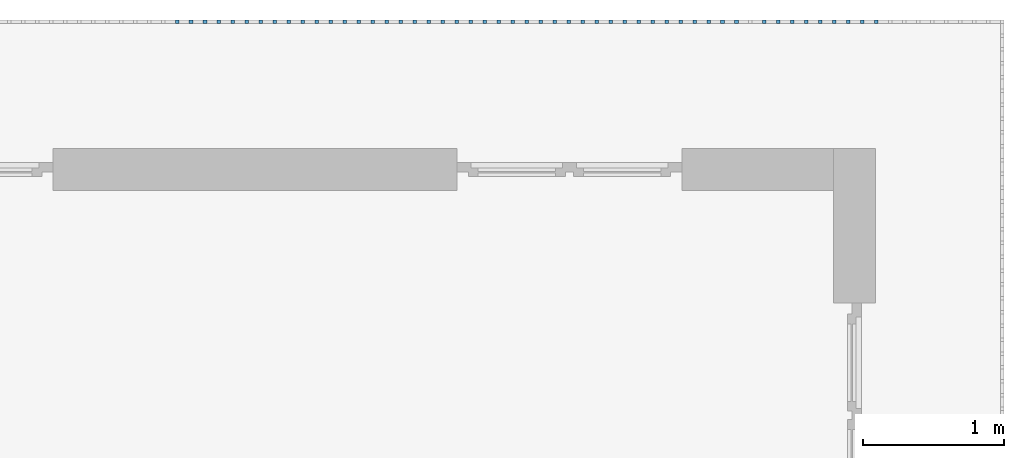
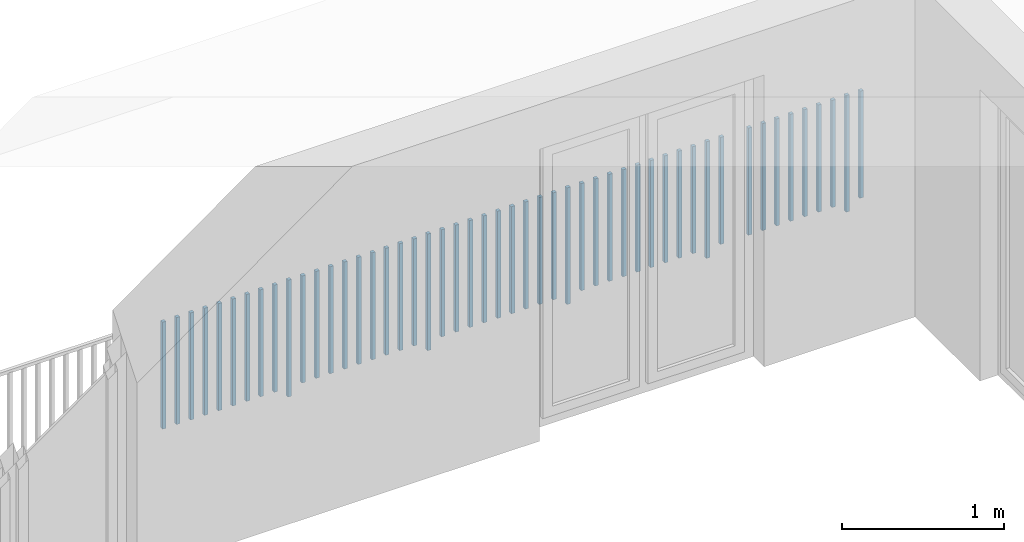
# One storey, part 47 of 48: 50 building element parts, 1 element without a shape of its own.
"""IFC4 building model written with IfcOpenShell, lengths in metres."""

import ifcopenshell
import ifcopenshell.guid

model = None  # the IFC model being written
_history = None  # IfcOwnerHistory: only IFC2X3 demands one
_inside = {}  # id of a spatial element -> (the spatial element, [elements in it])
_under = {}  # id of a project, library or spatial element -> (it, [spatial elements below it])
_declared = {}  # id of a project -> (the project, [libraries it declares])
_typed = {}  # id of a type object -> (the type object, [elements of that type])
_made_of = {}  # id of a material, layer set ... -> (it, [elements and type objects made of it])


def new_model(schema):
    """Start an empty IFC model of exactly this schema.

    Asked for "IFC4X3", IfcOpenShell would pick the latest addendum, in which some entities
    have other attributes; the version numbers below select the first issue.
    IFC2X3 requires an IfcOwnerHistory on every rooted entity: one is made here for all.
    """
    global model, _history
    if schema == "IFC4X3":
        model = ifcopenshell.file(schema_version=(4, 3, 0, 0))
    else:
        model = ifcopenshell.file(schema=schema)
    _inside.clear()
    _under.clear()
    _declared.clear()
    _typed.clear()
    _made_of.clear()
    _history = None
    if model.schema == "IFC2X3":
        org = make("IfcOrganization", Name="unknown")
        user = make(
            "IfcPersonAndOrganization",
            ThePerson=make("IfcPerson", FamilyName="unknown"),
            TheOrganization=org,
        )
        app = make(
            "IfcApplication",
            ApplicationDeveloper=org,
            Version="unknown",
            ApplicationFullName="unknown",
            ApplicationIdentifier="unknown",
        )
        _history = make(
            "IfcOwnerHistory",
            OwningUser=user,
            OwningApplication=app,
            ChangeAction="ADDED",
            CreationDate=0,
        )
    return model


def make(cls, **values):
    """One entity of the class cls with the attributes given. An attribute that is None is left unset."""
    return model.create_entity(
        cls, **{name: value for name, value in values.items() if value is not None}
    )


def entity(cls, *values):
    """Any entity or typed value of the class cls, its attributes in the order of the schema. None: left unset."""
    e = model.create_entity(cls)
    for i, value in enumerate(values):
        if value is not None:
            e[i] = value
    return e


def rooted(cls, **values):
    """An entity with a GlobalId (a new one), such as an element, a storey or a relation."""
    return make(cls, GlobalId=ifcopenshell.guid.new(), OwnerHistory=_history, **values)


def si_unit(unit_type, name, prefix=None):
    """IfcSIUnit, for example si_unit("LENGTHUNIT", "METRE", prefix="MILLI")."""
    return make("IfcSIUnit", UnitType=unit_type, Prefix=prefix, Name=name)


def converted_unit(unit_type, name, factor, base, dimensions=None, offset=None):
    """IfcConversionBasedUnit, such as the inch: factor (a typed value) times the base unit."""
    return make(
        "IfcConversionBasedUnit"
        if offset is None
        else "IfcConversionBasedUnitWithOffset",
        ConversionOffset=offset,
        Dimensions=None
        if dimensions is None
        else entity("IfcDimensionalExponents", *dimensions),
        UnitType=unit_type,
        Name=name,
        ConversionFactor=make(
            "IfcMeasureWithUnit", ValueComponent=factor, UnitComponent=base
        ),
    )


def derived_unit(unit_type, elements):
    """IfcDerivedUnit: a product of units, each with its exponent."""
    return make(
        "IfcDerivedUnit",
        Elements=[
            make("IfcDerivedUnitElement", Unit=unit, Exponent=power)
            for unit, power in elements
        ],
        UnitType=unit_type,
    )


def assignment(units):
    """IfcUnitAssignment: the units of a project."""
    return None if units is None else make("IfcUnitAssignment", Units=units)


def point(xyz):
    """IfcCartesianPoint."""
    return None if xyz is None else make("IfcCartesianPoint", Coordinates=xyz)


def direction(xyz):
    """IfcDirection."""
    return None if xyz is None else make("IfcDirection", DirectionRatios=xyz)


def frame(location, z_axis=None, x_axis=None):
    """IfcAxis2Placement3D, a coordinate frame: its origin and axes. An axis left out is left unset."""
    return make(
        "IfcAxis2Placement3D",
        Location=point(location),
        Axis=direction(z_axis),
        RefDirection=direction(x_axis),
    )


def origin_with_axes():
    """The frame at (0, 0, 0) with the z axis (0, 0, 1) and the x axis (1, 0, 0) written out."""
    return frame((0.0, 0.0, 0.0), z_axis=(0.0, 0.0, 1.0), x_axis=(1.0, 0.0, 0.0))


def place(relative_to, where):
    """IfcLocalPlacement: puts the frame where relative to a parent placement (None: the world)."""
    return make(
        "IfcLocalPlacement", PlacementRelTo=relative_to, RelativePlacement=where
    )


def context(
    kind, dimensions, precision=None, world=None, true_north=None, identifier=None
):
    """IfcGeometricRepresentationContext, for example the 3D "Model" context."""
    return make(
        "IfcGeometricRepresentationContext",
        ContextIdentifier=identifier,
        ContextType=kind,
        CoordinateSpaceDimension=dimensions,
        Precision=precision,
        WorldCoordinateSystem=world,
        TrueNorth=true_north,
    )


def subcontext(parent, identifier, kind, view, scale=None):
    """IfcGeometricRepresentationSubContext, for example "Body" below "Model"."""
    return make(
        "IfcGeometricRepresentationSubContext",
        ContextIdentifier=identifier,
        ContextType=kind,
        ParentContext=parent,
        TargetScale=scale,
        TargetView=view,
    )


def project(units=None, contexts=None):
    """IfcProject with its units and contexts."""
    return rooted(
        "IfcProject",
        Name="project",
        RepresentationContexts=contexts,
        UnitsInContext=assignment(units),
    )


def spatial(cls, under=None, at=None, **own):
    """A site, building, storey or space (cls), placed at a placement, below another one or the project."""
    s = rooted(cls, ObjectPlacement=at, **own)
    if under is not None:
        _under.setdefault(under.id(), (under, []))[1].append(s)
    return s


def point_list(points):
    """IfcCartesianPointList2D or 3D."""
    cls = (
        "IfcCartesianPointList2D" if len(points[0]) == 2 else "IfcCartesianPointList3D"
    )
    return make(cls, CoordList=points)


def polygons(points, faces, closed=None, point_numbers=None):
    """IfcPolygonalFaceSet: a face is its outer loop, then its inner loops; points numbered from 1."""
    made = []
    for loops in faces:
        if len(loops) == 1:
            made.append(make("IfcIndexedPolygonalFace", CoordIndex=loops[0]))
        else:
            made.append(
                make(
                    "IfcIndexedPolygonalFaceWithVoids",
                    CoordIndex=loops[0],
                    InnerCoordIndices=loops[1:],
                )
            )
    return make(
        "IfcPolygonalFaceSet",
        Coordinates=point_list(points),
        Closed=closed,
        Faces=made,
        PnIndex=point_numbers,
    )


def shape(context_of_items, identifier, shape_type, items):
    """IfcShapeRepresentation: the items that make up one representation, for example the "Body"."""
    return make(
        "IfcShapeRepresentation",
        ContextOfItems=context_of_items,
        RepresentationIdentifier=identifier,
        RepresentationType=shape_type,
        Items=items,
    )


def material(Name=None, Category=None):
    """IfcMaterial."""
    return make("IfcMaterial", Name=Name, Category=Category)


def made_of(thing, what):
    """Note that an element or type object is made of a material, layer set ...; save() writes the relation."""
    if what is not None:
        _made_of.setdefault(what.id(), (what, []))[1].append(thing)
    return thing


def type_object(cls, material=None, **own):
    """A type object (cls), such as IfcWallType, which elements share."""
    return made_of(rooted(cls, **own), material)


def element(
    cls,
    number,
    at=None,
    inside=None,
    cuts=None,
    type_object=None,
    material=None,
    context=None,
    identifier="Body",
    shape_type=None,
    held_by="IfcProductDefinitionShape",
    body=None,
    shapes=None,
    **own,
):
    """One element of the class cls, such as IfcWall. Its Tag is "e" and its number.

    at: its placement. inside: the storey or other place that contains it. cuts: it is an
    opening in that element (IfcRelVoidsElement). A single representation is given by context,
    identifier, shape_type and body (its items); several are given by shapes. held_by: the class
    of the entity that holds the representations. save() writes the other relations.
    """
    e = rooted(cls, Tag="e%d" % number, ObjectPlacement=at, **own)
    if body is not None:
        shapes = [shape(context, identifier, shape_type, body)]
    if shapes is not None:
        e.Representation = make(held_by, Representations=shapes)
    if inside is not None:
        _inside.setdefault(inside.id(), (inside, []))[1].append(e)
    if cuts is not None:
        rooted(
            "IfcRelVoidsElement", RelatingBuildingElement=cuts, RelatedOpeningElement=e
        )
    if type_object is not None:
        _typed.setdefault(type_object.id(), (type_object, []))[1].append(e)
    return made_of(e, material)


def aggregate(whole, parts):
    """IfcRelAggregates: a whole, such as a stair, and the parts it consists of."""
    return rooted("IfcRelAggregates", RelatingObject=whole, RelatedObjects=parts)


def save(model, path):
    """Write the relations noted so far, then the file.

    IfcRelAggregates (storeys below a building ...), IfcRelContainedInSpatialStructure (elements
    in a storey), IfcRelDefinesByType, IfcRelAssociatesMaterial and IfcRelDeclares: one each for
    every whole, place, type object, material and project.
    """
    for whole, parts in _under.values():
        aggregate(whole, parts)
    for where, things in _inside.values():
        rooted(
            "IfcRelContainedInSpatialStructure",
            RelatedElements=things,
            RelatingStructure=where,
        )
    for kind, things in _typed.values():
        rooted("IfcRelDefinesByType", RelatedObjects=things, RelatingType=kind)
    for what, things in _made_of.values():
        rooted("IfcRelAssociatesMaterial", RelatedObjects=things, RelatingMaterial=what)
    for by, libraries in _declared.values():
        rooted("IfcRelDeclares", RelatingContext=by, RelatedDefinitions=libraries)
    model.write(path)


model = new_model("IFC4")

# Units and contexts
model_context = context("Model", 3, precision=1e-05, world=origin_with_axes(), true_north=direction((0.0, 1.0)))
body_context = subcontext(model_context, "Body", "Model", "MODEL_VIEW")
ifc_project = project(units=[si_unit("LENGTHUNIT", "METRE"), si_unit("AREAUNIT", "SQUARE_METRE"), si_unit("VOLUMEUNIT", "CUBIC_METRE"), converted_unit("PLANEANGLEUNIT", "DEGREE", entity("IfcPlaneAngleMeasure", 0.0174532925199), si_unit("PLANEANGLEUNIT", "RADIAN"), dimensions=[0, 0, 0, 0, 0, 0, 0]), converted_unit("TIMEUNIT", "Year", entity("IfcTimeMeasure", 31556926.0), si_unit("TIMEUNIT", "SECOND"), dimensions=[0, 0, 1, 0, 0, 0, 0]), si_unit("MASSUNIT", "GRAM", prefix="KILO"), si_unit("THERMODYNAMICTEMPERATUREUNIT", "DEGREE_CELSIUS"), si_unit("LUMINOUSINTENSITYUNIT", "LUMEN"), si_unit("ENERGYUNIT", "JOULE", prefix="MEGA"), derived_unit("THERMALCONDUCTANCEUNIT", [(si_unit("POWERUNIT", "WATT"), 1), (si_unit("LENGTHUNIT", "METRE"), -1), (si_unit("THERMODYNAMICTEMPERATUREUNIT", "KELVIN"), -1)]), derived_unit("SPECIFICHEATCAPACITYUNIT", [(si_unit("ENERGYUNIT", "JOULE"), 1), (si_unit("MASSUNIT", "GRAM", prefix="KILO"), -1), (si_unit("THERMODYNAMICTEMPERATUREUNIT", "KELVIN"), -1)]), derived_unit("MASSDENSITYUNIT", [(si_unit("MASSUNIT", "GRAM", prefix="KILO"), 1), (si_unit("VOLUMEUNIT", "CUBIC_METRE"), -1)])], contexts=[model_context])

# Site, building, storey
site_placement = place(None, origin_with_axes())
site = spatial("IfcSite", under=ifc_project, at=site_placement, CompositionType="ELEMENT")
building_placement = place(site_placement, origin_with_axes())
building = spatial("IfcBuilding", under=site, at=building_placement, CompositionType="ELEMENT")
storey_placement = place(building_placement, frame((0.0, 0.0, 3.4), z_axis=(0.0, 0.0, 1.0), x_axis=(1.0, 0.0, 0.0)))
storey = spatial("IfcBuildingStorey", under=building, at=storey_placement, Name="1. Geschoss", CompositionType="ELEMENT", Elevation=3.4)

# Railing, building element parts
railing_type = type_object("IfcRailingType", PredefinedType="NOTDEFINED")
railing_placement = place(storey_placement, frame((10.2378006196, 9.82118776896, 0.0), z_axis=(0.0, 0.0, 1.0), x_axis=(1.0, 0.0, 0.0)))
railing = element("IfcRailing", 1, at=railing_placement, inside=storey, type_object=railing_type, PredefinedType="NOTDEFINED")
ifc_material = material()
building_element_part_1_placement = place(railing_placement, origin_with_axes())
building_element_part_1 = element("IfcBuildingElementPart", 2, at=building_element_part_1_placement, material=ifc_material, PredefinedType="NOTDEFINED", context=body_context, shape_type="Tessellation", body=[
    polygons([(-0.907804347826, 0.0125, 0.07), (-0.907804347826, -0.0125, 0.07), (-0.907804347826, -0.0125, 0.8775), (-0.907804347826, 0.0125, 0.8775), (-0.882804347826, 0.0125, 0.07), (-0.882804347826, -0.0125, 0.07), (-0.882804347826, -0.0125, 0.8775), (-0.882804347826, 0.0125, 0.8775)], [[[1, 2, 3, 4]], [[1, 5, 6, 2]], [[2, 6, 7, 3]], [[4, 3, 7, 8]], [[5, 1, 4, 8]], [[6, 5, 8, 7]]], closed=True),
])
building_element_part_2_placement = place(railing_placement, origin_with_axes())
building_element_part_2 = element("IfcBuildingElementPart", 3, at=building_element_part_2_placement, material=ifc_material, PredefinedType="NOTDEFINED", context=body_context, shape_type="Tessellation", body=[
    polygons([(-1.0072826087, 0.0125, 0.0), (-1.0072826087, -0.0125, 0.0), (-1.0072826087, -0.0125, 0.88), (-1.0072826087, 0.0125, 0.88), (-0.982282608696, 0.0125, 0.0), (-0.982282608696, -0.0125, 0.0), (-0.982282608696, -0.0125, 0.88), (-0.982282608696, 0.0125, 0.88)], [[[1, 2, 3, 4]], [[1, 5, 6, 2]], [[2, 6, 7, 3]], [[4, 3, 7, 8]], [[5, 1, 4, 8]], [[6, 5, 8, 7]]], closed=True),
])
building_element_part_3_placement = place(railing_placement, origin_with_axes())
building_element_part_3 = element("IfcBuildingElementPart", 4, at=building_element_part_3_placement, material=ifc_material, PredefinedType="NOTDEFINED", context=body_context, shape_type="Tessellation", body=[
    polygons([(-1.10676086957, 0.0125, 0.07), (-1.10676086957, -0.0125, 0.07), (-1.10676086957, -0.0125, 0.8775), (-1.10676086957, 0.0125, 0.8775), (-1.08176086957, 0.0125, 0.07), (-1.08176086957, -0.0125, 0.07), (-1.08176086957, -0.0125, 0.8775), (-1.08176086957, 0.0125, 0.8775)], [[[1, 2, 3, 4]], [[1, 5, 6, 2]], [[2, 6, 7, 3]], [[4, 3, 7, 8]], [[5, 1, 4, 8]], [[6, 5, 8, 7]]], closed=True),
])
building_element_part_4_placement = place(railing_placement, origin_with_axes())
building_element_part_4 = element("IfcBuildingElementPart", 5, at=building_element_part_4_placement, material=ifc_material, PredefinedType="NOTDEFINED", context=body_context, shape_type="Tessellation", body=[
    polygons([(-1.20623913043, 0.0125, 0.07), (-1.20623913043, -0.0125, 0.07), (-1.20623913043, -0.0125, 0.8775), (-1.20623913043, 0.0125, 0.8775), (-1.18123913043, 0.0125, 0.07), (-1.18123913043, -0.0125, 0.07), (-1.18123913043, -0.0125, 0.8775), (-1.18123913043, 0.0125, 0.8775)], [[[1, 2, 3, 4]], [[1, 5, 6, 2]], [[2, 6, 7, 3]], [[4, 3, 7, 8]], [[5, 1, 4, 8]], [[6, 5, 8, 7]]], closed=True),
])
building_element_part_5_placement = place(railing_placement, origin_with_axes())
building_element_part_5 = element("IfcBuildingElementPart", 6, at=building_element_part_5_placement, material=ifc_material, PredefinedType="NOTDEFINED", context=body_context, shape_type="Tessellation", body=[
    polygons([(-1.3057173913, 0.0125, 0.07), (-1.3057173913, -0.0125, 0.07), (-1.3057173913, -0.0125, 0.8775), (-1.3057173913, 0.0125, 0.8775), (-1.2807173913, 0.0125, 0.07), (-1.2807173913, -0.0125, 0.07), (-1.2807173913, -0.0125, 0.8775), (-1.2807173913, 0.0125, 0.8775)], [[[1, 2, 3, 4]], [[1, 5, 6, 2]], [[2, 6, 7, 3]], [[4, 3, 7, 8]], [[5, 1, 4, 8]], [[6, 5, 8, 7]]], closed=True),
])
building_element_part_6_placement = place(railing_placement, origin_with_axes())
building_element_part_6 = element("IfcBuildingElementPart", 7, at=building_element_part_6_placement, material=ifc_material, PredefinedType="NOTDEFINED", context=body_context, shape_type="Tessellation", body=[
    polygons([(-1.40519565217, 0.0125, 0.07), (-1.40519565217, -0.0125, 0.07), (-1.40519565217, -0.0125, 0.8775), (-1.40519565217, 0.0125, 0.8775), (-1.38019565217, 0.0125, 0.07), (-1.38019565217, -0.0125, 0.07), (-1.38019565217, -0.0125, 0.8775), (-1.38019565217, 0.0125, 0.8775)], [[[1, 2, 3, 4]], [[1, 5, 6, 2]], [[2, 6, 7, 3]], [[4, 3, 7, 8]], [[5, 1, 4, 8]], [[6, 5, 8, 7]]], closed=True),
])
building_element_part_7_placement = place(railing_placement, origin_with_axes())
building_element_part_7 = element("IfcBuildingElementPart", 8, at=building_element_part_7_placement, material=ifc_material, PredefinedType="NOTDEFINED", context=body_context, shape_type="Tessellation", body=[
    polygons([(-1.50467391304, 0.0125, 0.07), (-1.50467391304, -0.0125, 0.07), (-1.50467391304, -0.0125, 0.8775), (-1.50467391304, 0.0125, 0.8775), (-1.47967391304, 0.0125, 0.07), (-1.47967391304, -0.0125, 0.07), (-1.47967391304, -0.0125, 0.8775), (-1.47967391304, 0.0125, 0.8775)], [[[1, 2, 3, 4]], [[1, 5, 6, 2]], [[2, 6, 7, 3]], [[4, 3, 7, 8]], [[5, 1, 4, 8]], [[6, 5, 8, 7]]], closed=True),
])
building_element_part_8_placement = place(railing_placement, origin_with_axes())
building_element_part_8 = element("IfcBuildingElementPart", 9, at=building_element_part_8_placement, material=ifc_material, PredefinedType="NOTDEFINED", context=body_context, shape_type="Tessellation", body=[
    polygons([(-1.60415217391, 0.0125, 0.07), (-1.60415217391, -0.0125, 0.07), (-1.60415217391, -0.0125, 0.8775), (-1.60415217391, 0.0125, 0.8775), (-1.57915217391, 0.0125, 0.07), (-1.57915217391, -0.0125, 0.07), (-1.57915217391, -0.0125, 0.8775), (-1.57915217391, 0.0125, 0.8775)], [[[1, 2, 3, 4]], [[1, 5, 6, 2]], [[2, 6, 7, 3]], [[4, 3, 7, 8]], [[5, 1, 4, 8]], [[6, 5, 8, 7]]], closed=True),
])
building_element_part_9_placement = place(railing_placement, origin_with_axes())
building_element_part_9 = element("IfcBuildingElementPart", 10, at=building_element_part_9_placement, material=ifc_material, PredefinedType="NOTDEFINED", context=body_context, shape_type="Tessellation", body=[
    polygons([(-1.70363043478, 0.0125, 0.07), (-1.70363043478, -0.0125, 0.07), (-1.70363043478, -0.0125, 0.8775), (-1.70363043478, 0.0125, 0.8775), (-1.67863043478, 0.0125, 0.07), (-1.67863043478, -0.0125, 0.07), (-1.67863043478, -0.0125, 0.8775), (-1.67863043478, 0.0125, 0.8775)], [[[1, 2, 3, 4]], [[1, 5, 6, 2]], [[2, 6, 7, 3]], [[4, 3, 7, 8]], [[5, 1, 4, 8]], [[6, 5, 8, 7]]], closed=True),
])
building_element_part_10_placement = place(railing_placement, origin_with_axes())
building_element_part_10 = element("IfcBuildingElementPart", 11, at=building_element_part_10_placement, material=ifc_material, PredefinedType="NOTDEFINED", context=body_context, shape_type="Tessellation", body=[
    polygons([(-1.90258695652, 0.0125, 0.07), (-1.90258695652, -0.0125, 0.07), (-1.90258695652, -0.0125, 0.8775), (-1.90258695652, 0.0125, 0.8775), (-1.87758695652, 0.0125, 0.07), (-1.87758695652, -0.0125, 0.07), (-1.87758695652, -0.0125, 0.8775), (-1.87758695652, 0.0125, 0.8775)], [[[1, 2, 3, 4]], [[1, 5, 6, 2]], [[2, 6, 7, 3]], [[4, 3, 7, 8]], [[5, 1, 4, 8]], [[6, 5, 8, 7]]], closed=True),
])
building_element_part_11_placement = place(railing_placement, origin_with_axes())
building_element_part_11 = element("IfcBuildingElementPart", 12, at=building_element_part_11_placement, material=ifc_material, PredefinedType="NOTDEFINED", context=body_context, shape_type="Tessellation", body=[
    polygons([(-2.00206521739, 0.0125, 0.0), (-2.00206521739, -0.0125, 0.0), (-2.00206521739, -0.0125, 0.88), (-2.00206521739, 0.0125, 0.88), (-1.97706521739, 0.0125, 0.0), (-1.97706521739, -0.0125, 0.0), (-1.97706521739, -0.0125, 0.88), (-1.97706521739, 0.0125, 0.88)], [[[1, 2, 3, 4]], [[1, 5, 6, 2]], [[2, 6, 7, 3]], [[4, 3, 7, 8]], [[5, 1, 4, 8]], [[6, 5, 8, 7]]], closed=True),
])
building_element_part_12_placement = place(railing_placement, origin_with_axes())
building_element_part_12 = element("IfcBuildingElementPart", 13, at=building_element_part_12_placement, material=ifc_material, PredefinedType="NOTDEFINED", context=body_context, shape_type="Tessellation", body=[
    polygons([(-2.10154347826, 0.0125, 0.07), (-2.10154347826, -0.0125, 0.07), (-2.10154347826, -0.0125, 0.8775), (-2.10154347826, 0.0125, 0.8775), (-2.07654347826, 0.0125, 0.07), (-2.07654347826, -0.0125, 0.07), (-2.07654347826, -0.0125, 0.8775), (-2.07654347826, 0.0125, 0.8775)], [[[1, 2, 3, 4]], [[1, 5, 6, 2]], [[2, 6, 7, 3]], [[4, 3, 7, 8]], [[5, 1, 4, 8]], [[6, 5, 8, 7]]], closed=True),
])
building_element_part_13_placement = place(railing_placement, origin_with_axes())
building_element_part_13 = element("IfcBuildingElementPart", 14, at=building_element_part_13_placement, material=ifc_material, PredefinedType="NOTDEFINED", context=body_context, shape_type="Tessellation", body=[
    polygons([(-2.20102173913, 0.0125, 0.07), (-2.20102173913, -0.0125, 0.07), (-2.20102173913, -0.0125, 0.8775), (-2.20102173913, 0.0125, 0.8775), (-2.17602173913, 0.0125, 0.07), (-2.17602173913, -0.0125, 0.07), (-2.17602173913, -0.0125, 0.8775), (-2.17602173913, 0.0125, 0.8775)], [[[1, 2, 3, 4]], [[1, 5, 6, 2]], [[2, 6, 7, 3]], [[4, 3, 7, 8]], [[5, 1, 4, 8]], [[6, 5, 8, 7]]], closed=True),
])
building_element_part_14_placement = place(railing_placement, origin_with_axes())
building_element_part_14 = element("IfcBuildingElementPart", 15, at=building_element_part_14_placement, material=ifc_material, PredefinedType="NOTDEFINED", context=body_context, shape_type="Tessellation", body=[
    polygons([(-2.3005, 0.0125, 0.07), (-2.3005, -0.0125, 0.07), (-2.3005, -0.0125, 0.8775), (-2.3005, 0.0125, 0.8775), (-2.2755, 0.0125, 0.07), (-2.2755, -0.0125, 0.07), (-2.2755, -0.0125, 0.8775), (-2.2755, 0.0125, 0.8775)], [[[1, 2, 3, 4]], [[1, 5, 6, 2]], [[2, 6, 7, 3]], [[4, 3, 7, 8]], [[5, 1, 4, 8]], [[6, 5, 8, 7]]], closed=True),
])
building_element_part_15_placement = place(railing_placement, origin_with_axes())
building_element_part_15 = element("IfcBuildingElementPart", 16, at=building_element_part_15_placement, material=ifc_material, PredefinedType="NOTDEFINED", context=body_context, shape_type="Tessellation", body=[
    polygons([(-2.39997826087, 0.0125, 0.07), (-2.39997826087, -0.0125, 0.07), (-2.39997826087, -0.0125, 0.8775), (-2.39997826087, 0.0125, 0.8775), (-2.37497826087, 0.0125, 0.07), (-2.37497826087, -0.0125, 0.07), (-2.37497826087, -0.0125, 0.8775), (-2.37497826087, 0.0125, 0.8775)], [[[1, 2, 3, 4]], [[1, 5, 6, 2]], [[2, 6, 7, 3]], [[4, 3, 7, 8]], [[5, 1, 4, 8]], [[6, 5, 8, 7]]], closed=True),
])
building_element_part_16_placement = place(railing_placement, origin_with_axes())
building_element_part_16 = element("IfcBuildingElementPart", 17, at=building_element_part_16_placement, material=ifc_material, PredefinedType="NOTDEFINED", context=body_context, shape_type="Tessellation", body=[
    polygons([(-2.49945652174, 0.0125, 0.07), (-2.49945652174, -0.0125, 0.07), (-2.49945652174, -0.0125, 0.8775), (-2.49945652174, 0.0125, 0.8775), (-2.47445652174, 0.0125, 0.07), (-2.47445652174, -0.0125, 0.07), (-2.47445652174, -0.0125, 0.8775), (-2.47445652174, 0.0125, 0.8775)], [[[1, 2, 3, 4]], [[1, 5, 6, 2]], [[2, 6, 7, 3]], [[4, 3, 7, 8]], [[5, 1, 4, 8]], [[6, 5, 8, 7]]], closed=True),
])
building_element_part_17_placement = place(railing_placement, origin_with_axes())
building_element_part_17 = element("IfcBuildingElementPart", 18, at=building_element_part_17_placement, material=ifc_material, PredefinedType="NOTDEFINED", context=body_context, shape_type="Tessellation", body=[
    polygons([(-2.59893478261, 0.0125, 0.07), (-2.59893478261, -0.0125, 0.07), (-2.59893478261, -0.0125, 0.8775), (-2.59893478261, 0.0125, 0.8775), (-2.57393478261, 0.0125, 0.07), (-2.57393478261, -0.0125, 0.07), (-2.57393478261, -0.0125, 0.8775), (-2.57393478261, 0.0125, 0.8775)], [[[1, 2, 3, 4]], [[1, 5, 6, 2]], [[2, 6, 7, 3]], [[4, 3, 7, 8]], [[5, 1, 4, 8]], [[6, 5, 8, 7]]], closed=True),
])
building_element_part_18_placement = place(railing_placement, origin_with_axes())
building_element_part_18 = element("IfcBuildingElementPart", 19, at=building_element_part_18_placement, material=ifc_material, PredefinedType="NOTDEFINED", context=body_context, shape_type="Tessellation", body=[
    polygons([(-2.69841304348, 0.0125, 0.07), (-2.69841304348, -0.0125, 0.07), (-2.69841304348, -0.0125, 0.8775), (-2.69841304348, 0.0125, 0.8775), (-2.67341304348, 0.0125, 0.07), (-2.67341304348, -0.0125, 0.07), (-2.67341304348, -0.0125, 0.8775), (-2.67341304348, 0.0125, 0.8775)], [[[1, 2, 3, 4]], [[1, 5, 6, 2]], [[2, 6, 7, 3]], [[4, 3, 7, 8]], [[5, 1, 4, 8]], [[6, 5, 8, 7]]], closed=True),
])
building_element_part_19_placement = place(railing_placement, origin_with_axes())
building_element_part_19 = element("IfcBuildingElementPart", 20, at=building_element_part_19_placement, material=ifc_material, PredefinedType="NOTDEFINED", context=body_context, shape_type="Tessellation", body=[
    polygons([(-2.79789130435, 0.0125, 0.07), (-2.79789130435, -0.0125, 0.07), (-2.79789130435, -0.0125, 0.8775), (-2.79789130435, 0.0125, 0.8775), (-2.77289130435, 0.0125, 0.07), (-2.77289130435, -0.0125, 0.07), (-2.77289130435, -0.0125, 0.8775), (-2.77289130435, 0.0125, 0.8775)], [[[1, 2, 3, 4]], [[1, 5, 6, 2]], [[2, 6, 7, 3]], [[4, 3, 7, 8]], [[5, 1, 4, 8]], [[6, 5, 8, 7]]], closed=True),
])
building_element_part_20_placement = place(railing_placement, origin_with_axes())
building_element_part_20 = element("IfcBuildingElementPart", 21, at=building_element_part_20_placement, material=ifc_material, PredefinedType="NOTDEFINED", context=body_context, shape_type="Tessellation", body=[
    polygons([(-2.89736956522, 0.0125, 0.07), (-2.89736956522, -0.0125, 0.07), (-2.89736956522, -0.0125, 0.8775), (-2.89736956522, 0.0125, 0.8775), (-2.87236956522, 0.0125, 0.07), (-2.87236956522, -0.0125, 0.07), (-2.87236956522, -0.0125, 0.8775), (-2.87236956522, 0.0125, 0.8775)], [[[1, 2, 3, 4]], [[1, 5, 6, 2]], [[2, 6, 7, 3]], [[4, 3, 7, 8]], [[5, 1, 4, 8]], [[6, 5, 8, 7]]], closed=True),
])
building_element_part_21_placement = place(railing_placement, origin_with_axes())
building_element_part_21 = element("IfcBuildingElementPart", 22, at=building_element_part_21_placement, material=ifc_material, PredefinedType="NOTDEFINED", context=body_context, shape_type="Tessellation", body=[
    polygons([(-2.99684782609, 0.0125, 0.0), (-2.99684782609, -0.0125, 0.0), (-2.99684782609, -0.0125, 0.88), (-2.99684782609, 0.0125, 0.88), (-2.97184782609, 0.0125, 0.0), (-2.97184782609, -0.0125, 0.0), (-2.97184782609, -0.0125, 0.88), (-2.97184782609, 0.0125, 0.88)], [[[1, 2, 3, 4]], [[1, 5, 6, 2]], [[2, 6, 7, 3]], [[4, 3, 7, 8]], [[5, 1, 4, 8]], [[6, 5, 8, 7]]], closed=True),
])
building_element_part_22_placement = place(railing_placement, origin_with_axes())
building_element_part_22 = element("IfcBuildingElementPart", 23, at=building_element_part_22_placement, material=ifc_material, PredefinedType="NOTDEFINED", context=body_context, shape_type="Tessellation", body=[
    polygons([(-3.09632608696, 0.0125, 0.07), (-3.09632608696, -0.0125, 0.07), (-3.09632608696, -0.0125, 0.8775), (-3.09632608696, 0.0125, 0.8775), (-3.07132608696, 0.0125, 0.07), (-3.07132608696, -0.0125, 0.07), (-3.07132608696, -0.0125, 0.8775), (-3.07132608696, 0.0125, 0.8775)], [[[1, 2, 3, 4]], [[1, 5, 6, 2]], [[2, 6, 7, 3]], [[4, 3, 7, 8]], [[5, 1, 4, 8]], [[6, 5, 8, 7]]], closed=True),
])
building_element_part_23_placement = place(railing_placement, origin_with_axes())
building_element_part_23 = element("IfcBuildingElementPart", 24, at=building_element_part_23_placement, material=ifc_material, PredefinedType="NOTDEFINED", context=body_context, shape_type="Tessellation", body=[
    polygons([(-3.19580434783, 0.0125, 0.07), (-3.19580434783, -0.0125, 0.07), (-3.19580434783, -0.0125, 0.8775), (-3.19580434783, 0.0125, 0.8775), (-3.17080434783, 0.0125, 0.07), (-3.17080434783, -0.0125, 0.07), (-3.17080434783, -0.0125, 0.8775), (-3.17080434783, 0.0125, 0.8775)], [[[1, 2, 3, 4]], [[1, 5, 6, 2]], [[2, 6, 7, 3]], [[4, 3, 7, 8]], [[5, 1, 4, 8]], [[6, 5, 8, 7]]], closed=True),
])
building_element_part_24_placement = place(railing_placement, origin_with_axes())
building_element_part_24 = element("IfcBuildingElementPart", 25, at=building_element_part_24_placement, material=ifc_material, PredefinedType="NOTDEFINED", context=body_context, shape_type="Tessellation", body=[
    polygons([(-3.2952826087, 0.0125, 0.07), (-3.2952826087, -0.0125, 0.07), (-3.2952826087, -0.0125, 0.8775), (-3.2952826087, 0.0125, 0.8775), (-3.2702826087, 0.0125, 0.07), (-3.2702826087, -0.0125, 0.07), (-3.2702826087, -0.0125, 0.8775), (-3.2702826087, 0.0125, 0.8775)], [[[1, 2, 3, 4]], [[1, 5, 6, 2]], [[2, 6, 7, 3]], [[4, 3, 7, 8]], [[5, 1, 4, 8]], [[6, 5, 8, 7]]], closed=True),
])
building_element_part_25_placement = place(railing_placement, origin_with_axes())
building_element_part_25 = element("IfcBuildingElementPart", 26, at=building_element_part_25_placement, material=ifc_material, PredefinedType="NOTDEFINED", context=body_context, shape_type="Tessellation", body=[
    polygons([(-3.39476086957, 0.0125, 0.07), (-3.39476086957, -0.0125, 0.07), (-3.39476086957, -0.0125, 0.8775), (-3.39476086957, 0.0125, 0.8775), (-3.36976086957, 0.0125, 0.07), (-3.36976086957, -0.0125, 0.07), (-3.36976086957, -0.0125, 0.8775), (-3.36976086957, 0.0125, 0.8775)], [[[1, 2, 3, 4]], [[1, 5, 6, 2]], [[2, 6, 7, 3]], [[4, 3, 7, 8]], [[5, 1, 4, 8]], [[6, 5, 8, 7]]], closed=True),
])
building_element_part_26_placement = place(railing_placement, origin_with_axes())
building_element_part_26 = element("IfcBuildingElementPart", 27, at=building_element_part_26_placement, material=ifc_material, PredefinedType="NOTDEFINED", context=body_context, shape_type="Tessellation", body=[
    polygons([(-3.49423913043, 0.0125, 0.07), (-3.49423913043, -0.0125, 0.07), (-3.49423913043, -0.0125, 0.8775), (-3.49423913043, 0.0125, 0.8775), (-3.46923913043, 0.0125, 0.07), (-3.46923913043, -0.0125, 0.07), (-3.46923913043, -0.0125, 0.8775), (-3.46923913043, 0.0125, 0.8775)], [[[1, 2, 3, 4]], [[1, 5, 6, 2]], [[2, 6, 7, 3]], [[4, 3, 7, 8]], [[5, 1, 4, 8]], [[6, 5, 8, 7]]], closed=True),
])
building_element_part_27_placement = place(railing_placement, origin_with_axes())
building_element_part_27 = element("IfcBuildingElementPart", 28, at=building_element_part_27_placement, material=ifc_material, PredefinedType="NOTDEFINED", context=body_context, shape_type="Tessellation", body=[
    polygons([(-3.5937173913, 0.0125, 0.07), (-3.5937173913, -0.0125, 0.07), (-3.5937173913, -0.0125, 0.8775), (-3.5937173913, 0.0125, 0.8775), (-3.5687173913, 0.0125, 0.07), (-3.5687173913, -0.0125, 0.07), (-3.5687173913, -0.0125, 0.8775), (-3.5687173913, 0.0125, 0.8775)], [[[1, 2, 3, 4]], [[1, 5, 6, 2]], [[2, 6, 7, 3]], [[4, 3, 7, 8]], [[5, 1, 4, 8]], [[6, 5, 8, 7]]], closed=True),
])
building_element_part_28_placement = place(railing_placement, origin_with_axes())
building_element_part_28 = element("IfcBuildingElementPart", 29, at=building_element_part_28_placement, material=ifc_material, PredefinedType="NOTDEFINED", context=body_context, shape_type="Tessellation", body=[
    polygons([(-3.69319565217, 0.0125, 0.07), (-3.69319565217, -0.0125, 0.07), (-3.69319565217, -0.0125, 0.8775), (-3.69319565217, 0.0125, 0.8775), (-3.66819565217, 0.0125, 0.07), (-3.66819565217, -0.0125, 0.07), (-3.66819565217, -0.0125, 0.8775), (-3.66819565217, 0.0125, 0.8775)], [[[1, 2, 3, 4]], [[1, 5, 6, 2]], [[2, 6, 7, 3]], [[4, 3, 7, 8]], [[5, 1, 4, 8]], [[6, 5, 8, 7]]], closed=True),
])
building_element_part_29_placement = place(railing_placement, origin_with_axes())
building_element_part_29 = element("IfcBuildingElementPart", 30, at=building_element_part_29_placement, material=ifc_material, PredefinedType="NOTDEFINED", context=body_context, shape_type="Tessellation", body=[
    polygons([(-3.79267391304, 0.0125, 0.07), (-3.79267391304, -0.0125, 0.07), (-3.79267391304, -0.0125, 0.8775), (-3.79267391304, 0.0125, 0.8775), (-3.76767391304, 0.0125, 0.07), (-3.76767391304, -0.0125, 0.07), (-3.76767391304, -0.0125, 0.8775), (-3.76767391304, 0.0125, 0.8775)], [[[1, 2, 3, 4]], [[1, 5, 6, 2]], [[2, 6, 7, 3]], [[4, 3, 7, 8]], [[5, 1, 4, 8]], [[6, 5, 8, 7]]], closed=True),
])
building_element_part_30_placement = place(railing_placement, origin_with_axes())
building_element_part_30 = element("IfcBuildingElementPart", 31, at=building_element_part_30_placement, material=ifc_material, PredefinedType="NOTDEFINED", context=body_context, shape_type="Tessellation", body=[
    polygons([(-3.89215217391, 0.0125, 0.07), (-3.89215217391, -0.0125, 0.07), (-3.89215217391, -0.0125, 0.8775), (-3.89215217391, 0.0125, 0.8775), (-3.86715217391, 0.0125, 0.07), (-3.86715217391, -0.0125, 0.07), (-3.86715217391, -0.0125, 0.8775), (-3.86715217391, 0.0125, 0.8775)], [[[1, 2, 3, 4]], [[1, 5, 6, 2]], [[2, 6, 7, 3]], [[4, 3, 7, 8]], [[5, 1, 4, 8]], [[6, 5, 8, 7]]], closed=True),
])
building_element_part_31_placement = place(railing_placement, origin_with_axes())
building_element_part_31 = element("IfcBuildingElementPart", 32, at=building_element_part_31_placement, material=ifc_material, PredefinedType="NOTDEFINED", context=body_context, shape_type="Tessellation", body=[
    polygons([(-3.99163043478, 0.0125, 0.0), (-3.99163043478, -0.0125, 0.0), (-3.99163043478, -0.0125, 0.88), (-3.99163043478, 0.0125, 0.88), (-3.96663043478, 0.0125, 0.0), (-3.96663043478, -0.0125, 0.0), (-3.96663043478, -0.0125, 0.88), (-3.96663043478, 0.0125, 0.88)], [[[1, 2, 3, 4]], [[1, 5, 6, 2]], [[2, 6, 7, 3]], [[4, 3, 7, 8]], [[5, 1, 4, 8]], [[6, 5, 8, 7]]], closed=True),
])
building_element_part_32_placement = place(railing_placement, origin_with_axes())
building_element_part_32 = element("IfcBuildingElementPart", 33, at=building_element_part_32_placement, material=ifc_material, PredefinedType="NOTDEFINED", context=body_context, shape_type="Tessellation", body=[
    polygons([(-4.09110869565, 0.0125, 0.07), (-4.09110869565, -0.0125, 0.07), (-4.09110869565, -0.0125, 0.8775), (-4.09110869565, 0.0125, 0.8775), (-4.06610869565, 0.0125, 0.07), (-4.06610869565, -0.0125, 0.07), (-4.06610869565, -0.0125, 0.8775), (-4.06610869565, 0.0125, 0.8775)], [[[1, 2, 3, 4]], [[1, 5, 6, 2]], [[2, 6, 7, 3]], [[4, 3, 7, 8]], [[5, 1, 4, 8]], [[6, 5, 8, 7]]], closed=True),
])
building_element_part_33_placement = place(railing_placement, origin_with_axes())
building_element_part_33 = element("IfcBuildingElementPart", 34, at=building_element_part_33_placement, material=ifc_material, PredefinedType="NOTDEFINED", context=body_context, shape_type="Tessellation", body=[
    polygons([(-4.19058695652, 0.0125, 0.07), (-4.19058695652, -0.0125, 0.07), (-4.19058695652, -0.0125, 0.8775), (-4.19058695652, 0.0125, 0.8775), (-4.16558695652, 0.0125, 0.07), (-4.16558695652, -0.0125, 0.07), (-4.16558695652, -0.0125, 0.8775), (-4.16558695652, 0.0125, 0.8775)], [[[1, 2, 3, 4]], [[1, 5, 6, 2]], [[2, 6, 7, 3]], [[4, 3, 7, 8]], [[5, 1, 4, 8]], [[6, 5, 8, 7]]], closed=True),
])
building_element_part_34_placement = place(railing_placement, origin_with_axes())
building_element_part_34 = element("IfcBuildingElementPart", 35, at=building_element_part_34_placement, material=ifc_material, PredefinedType="NOTDEFINED", context=body_context, shape_type="Tessellation", body=[
    polygons([(-4.29006521739, 0.0125, 0.07), (-4.29006521739, -0.0125, 0.07), (-4.29006521739, -0.0125, 0.8775), (-4.29006521739, 0.0125, 0.8775), (-4.26506521739, 0.0125, 0.07), (-4.26506521739, -0.0125, 0.07), (-4.26506521739, -0.0125, 0.8775), (-4.26506521739, 0.0125, 0.8775)], [[[1, 2, 3, 4]], [[1, 5, 6, 2]], [[2, 6, 7, 3]], [[4, 3, 7, 8]], [[5, 1, 4, 8]], [[6, 5, 8, 7]]], closed=True),
])
building_element_part_35_placement = place(railing_placement, origin_with_axes())
building_element_part_35 = element("IfcBuildingElementPart", 36, at=building_element_part_35_placement, material=ifc_material, PredefinedType="NOTDEFINED", context=body_context, shape_type="Tessellation", body=[
    polygons([(-4.38954347826, 0.0125, 0.07), (-4.38954347826, -0.0125, 0.07), (-4.38954347826, -0.0125, 0.8775), (-4.38954347826, 0.0125, 0.8775), (-4.36454347826, 0.0125, 0.07), (-4.36454347826, -0.0125, 0.07), (-4.36454347826, -0.0125, 0.8775), (-4.36454347826, 0.0125, 0.8775)], [[[1, 2, 3, 4]], [[1, 5, 6, 2]], [[2, 6, 7, 3]], [[4, 3, 7, 8]], [[5, 1, 4, 8]], [[6, 5, 8, 7]]], closed=True),
])
building_element_part_36_placement = place(railing_placement, origin_with_axes())
building_element_part_36 = element("IfcBuildingElementPart", 37, at=building_element_part_36_placement, material=ifc_material, PredefinedType="NOTDEFINED", context=body_context, shape_type="Tessellation", body=[
    polygons([(-4.48902173913, 0.0125, 0.07), (-4.48902173913, -0.0125, 0.07), (-4.48902173913, -0.0125, 0.8775), (-4.48902173913, 0.0125, 0.8775), (-4.46402173913, 0.0125, 0.07), (-4.46402173913, -0.0125, 0.07), (-4.46402173913, -0.0125, 0.8775), (-4.46402173913, 0.0125, 0.8775)], [[[1, 2, 3, 4]], [[1, 5, 6, 2]], [[2, 6, 7, 3]], [[4, 3, 7, 8]], [[5, 1, 4, 8]], [[6, 5, 8, 7]]], closed=True),
])
building_element_part_37_placement = place(railing_placement, origin_with_axes())
building_element_part_37 = element("IfcBuildingElementPart", 38, at=building_element_part_37_placement, material=ifc_material, PredefinedType="NOTDEFINED", context=body_context, shape_type="Tessellation", body=[
    polygons([(-4.5885, 0.0125, 0.07), (-4.5885, -0.0125, 0.07), (-4.5885, -0.0125, 0.8775), (-4.5885, 0.0125, 0.8775), (-4.5635, 0.0125, 0.07), (-4.5635, -0.0125, 0.07), (-4.5635, -0.0125, 0.8775), (-4.5635, 0.0125, 0.8775)], [[[1, 2, 3, 4]], [[1, 5, 6, 2]], [[2, 6, 7, 3]], [[4, 3, 7, 8]], [[5, 1, 4, 8]], [[6, 5, 8, 7]]], closed=True),
])
building_element_part_38_placement = place(railing_placement, origin_with_axes())
building_element_part_38 = element("IfcBuildingElementPart", 39, at=building_element_part_38_placement, material=ifc_material, PredefinedType="NOTDEFINED", context=body_context, shape_type="Tessellation", body=[
    polygons([(-4.68797826087, 0.0125, 0.07), (-4.68797826087, -0.0125, 0.07), (-4.68797826087, -0.0125, 0.8775), (-4.68797826087, 0.0125, 0.8775), (-4.66297826087, 0.0125, 0.07), (-4.66297826087, -0.0125, 0.07), (-4.66297826087, -0.0125, 0.8775), (-4.66297826087, 0.0125, 0.8775)], [[[1, 2, 3, 4]], [[1, 5, 6, 2]], [[2, 6, 7, 3]], [[4, 3, 7, 8]], [[5, 1, 4, 8]], [[6, 5, 8, 7]]], closed=True),
])
building_element_part_39_placement = place(railing_placement, origin_with_axes())
building_element_part_39 = element("IfcBuildingElementPart", 40, at=building_element_part_39_placement, material=ifc_material, PredefinedType="NOTDEFINED", context=body_context, shape_type="Tessellation", body=[
    polygons([(-4.78745652174, 0.0125, 0.07), (-4.78745652174, -0.0125, 0.07), (-4.78745652174, -0.0125, 0.8775), (-4.78745652174, 0.0125, 0.8775), (-4.76245652174, 0.0125, 0.07), (-4.76245652174, -0.0125, 0.07), (-4.76245652174, -0.0125, 0.8775), (-4.76245652174, 0.0125, 0.8775)], [[[1, 2, 3, 4]], [[1, 5, 6, 2]], [[2, 6, 7, 3]], [[4, 3, 7, 8]], [[5, 1, 4, 8]], [[6, 5, 8, 7]]], closed=True),
])
building_element_part_40_placement = place(railing_placement, origin_with_axes())
building_element_part_40 = element("IfcBuildingElementPart", 41, at=building_element_part_40_placement, material=ifc_material, PredefinedType="NOTDEFINED", context=body_context, shape_type="Tessellation", body=[
    polygons([(-4.88693478261, 0.0125, 0.07), (-4.88693478261, -0.0125, 0.07), (-4.88693478261, -0.0125, 0.8775), (-4.88693478261, 0.0125, 0.8775), (-4.86193478261, 0.0125, 0.07), (-4.86193478261, -0.0125, 0.07), (-4.86193478261, -0.0125, 0.8775), (-4.86193478261, 0.0125, 0.8775)], [[[1, 2, 3, 4]], [[1, 5, 6, 2]], [[2, 6, 7, 3]], [[4, 3, 7, 8]], [[5, 1, 4, 8]], [[6, 5, 8, 7]]], closed=True),
])
building_element_part_41_placement = place(railing_placement, origin_with_axes())
building_element_part_41 = element("IfcBuildingElementPart", 42, at=building_element_part_41_placement, material=ifc_material, PredefinedType="NOTDEFINED", context=body_context, shape_type="Tessellation", body=[
    polygons([(-4.98641304348, 0.0125, 0.0), (-4.98641304348, -0.0125, 0.0), (-4.98641304348, -0.0125, 0.88), (-4.98641304348, 0.0125, 0.88), (-4.96141304348, 0.0125, 0.0), (-4.96141304348, -0.0125, 0.0), (-4.96141304348, -0.0125, 0.88), (-4.96141304348, 0.0125, 0.88)], [[[1, 2, 3, 4]], [[1, 5, 6, 2]], [[2, 6, 7, 3]], [[4, 3, 7, 8]], [[5, 1, 4, 8]], [[6, 5, 8, 7]]], closed=True),
])
building_element_part_42_placement = place(railing_placement, origin_with_axes())
building_element_part_42 = element("IfcBuildingElementPart", 43, at=building_element_part_42_placement, material=ifc_material, PredefinedType="NOTDEFINED", context=body_context, shape_type="Tessellation", body=[
    polygons([(-5.08589130435, 0.0125, 0.07), (-5.08589130435, -0.0125, 0.07), (-5.08589130435, -0.0125, 0.8775), (-5.08589130435, 0.0125, 0.8775), (-5.06089130435, 0.0125, 0.07), (-5.06089130435, -0.0125, 0.07), (-5.06089130435, -0.0125, 0.8775), (-5.06089130435, 0.0125, 0.8775)], [[[1, 2, 3, 4]], [[1, 5, 6, 2]], [[2, 6, 7, 3]], [[4, 3, 7, 8]], [[5, 1, 4, 8]], [[6, 5, 8, 7]]], closed=True),
])
building_element_part_43_placement = place(railing_placement, origin_with_axes())
building_element_part_43 = element("IfcBuildingElementPart", 44, at=building_element_part_43_placement, material=ifc_material, PredefinedType="NOTDEFINED", context=body_context, shape_type="Tessellation", body=[
    polygons([(-5.18536956522, 0.0125, 0.07), (-5.18536956522, -0.0125, 0.07), (-5.18536956522, -0.0125, 0.8775), (-5.18536956522, 0.0125, 0.8775), (-5.16036956522, 0.0125, 0.07), (-5.16036956522, -0.0125, 0.07), (-5.16036956522, -0.0125, 0.8775), (-5.16036956522, 0.0125, 0.8775)], [[[1, 2, 3, 4]], [[1, 5, 6, 2]], [[2, 6, 7, 3]], [[4, 3, 7, 8]], [[5, 1, 4, 8]], [[6, 5, 8, 7]]], closed=True),
])
building_element_part_44_placement = place(railing_placement, origin_with_axes())
building_element_part_44 = element("IfcBuildingElementPart", 45, at=building_element_part_44_placement, material=ifc_material, PredefinedType="NOTDEFINED", context=body_context, shape_type="Tessellation", body=[
    polygons([(-5.28484782609, 0.0125, 0.07), (-5.28484782609, -0.0125, 0.07), (-5.28484782609, -0.0125, 0.8775), (-5.28484782609, 0.0125, 0.8775), (-5.25984782609, 0.0125, 0.07), (-5.25984782609, -0.0125, 0.07), (-5.25984782609, -0.0125, 0.8775), (-5.25984782609, 0.0125, 0.8775)], [[[1, 2, 3, 4]], [[1, 5, 6, 2]], [[2, 6, 7, 3]], [[4, 3, 7, 8]], [[5, 1, 4, 8]], [[6, 5, 8, 7]]], closed=True),
])
building_element_part_45_placement = place(railing_placement, origin_with_axes())
building_element_part_45 = element("IfcBuildingElementPart", 46, at=building_element_part_45_placement, material=ifc_material, PredefinedType="NOTDEFINED", context=body_context, shape_type="Tessellation", body=[
    polygons([(-5.38432608696, 0.0125, 0.07), (-5.38432608696, -0.0125, 0.07), (-5.38432608696, -0.0125, 0.8775), (-5.38432608696, 0.0125, 0.8775), (-5.35932608696, 0.0125, 0.07), (-5.35932608696, -0.0125, 0.07), (-5.35932608696, -0.0125, 0.8775), (-5.35932608696, 0.0125, 0.8775)], [[[1, 2, 3, 4]], [[1, 5, 6, 2]], [[2, 6, 7, 3]], [[4, 3, 7, 8]], [[5, 1, 4, 8]], [[6, 5, 8, 7]]], closed=True),
])
building_element_part_46_placement = place(railing_placement, origin_with_axes())
building_element_part_46 = element("IfcBuildingElementPart", 47, at=building_element_part_46_placement, material=ifc_material, PredefinedType="NOTDEFINED", context=body_context, shape_type="Tessellation", body=[
    polygons([(-5.48380434783, 0.0125, 0.07), (-5.48380434783, -0.0125, 0.07), (-5.48380434783, -0.0125, 0.8775), (-5.48380434783, 0.0125, 0.8775), (-5.45880434783, 0.0125, 0.07), (-5.45880434783, -0.0125, 0.07), (-5.45880434783, -0.0125, 0.8775), (-5.45880434783, 0.0125, 0.8775)], [[[1, 2, 3, 4]], [[1, 5, 6, 2]], [[2, 6, 7, 3]], [[4, 3, 7, 8]], [[5, 1, 4, 8]], [[6, 5, 8, 7]]], closed=True),
])
building_element_part_47_placement = place(railing_placement, origin_with_axes())
building_element_part_47 = element("IfcBuildingElementPart", 48, at=building_element_part_47_placement, material=ifc_material, PredefinedType="NOTDEFINED", context=body_context, shape_type="Tessellation", body=[
    polygons([(-5.5832826087, 0.0125, 0.07), (-5.5832826087, -0.0125, 0.07), (-5.5832826087, -0.0125, 0.8775), (-5.5832826087, 0.0125, 0.8775), (-5.5582826087, 0.0125, 0.07), (-5.5582826087, -0.0125, 0.07), (-5.5582826087, -0.0125, 0.8775), (-5.5582826087, 0.0125, 0.8775)], [[[1, 2, 3, 4]], [[1, 5, 6, 2]], [[2, 6, 7, 3]], [[4, 3, 7, 8]], [[5, 1, 4, 8]], [[6, 5, 8, 7]]], closed=True),
])
building_element_part_48_placement = place(railing_placement, origin_with_axes())
building_element_part_48 = element("IfcBuildingElementPart", 49, at=building_element_part_48_placement, material=ifc_material, PredefinedType="NOTDEFINED", context=body_context, shape_type="Tessellation", body=[
    polygons([(-5.68276086957, 0.0125, 0.07), (-5.68276086957, -0.0125, 0.07), (-5.68276086957, -0.0125, 0.8775), (-5.68276086957, 0.0125, 0.8775), (-5.65776086957, 0.0125, 0.07), (-5.65776086957, -0.0125, 0.07), (-5.65776086957, -0.0125, 0.8775), (-5.65776086957, 0.0125, 0.8775)], [[[1, 2, 3, 4]], [[1, 5, 6, 2]], [[2, 6, 7, 3]], [[4, 3, 7, 8]], [[5, 1, 4, 8]], [[6, 5, 8, 7]]], closed=True),
])
building_element_part_49_placement = place(railing_placement, origin_with_axes())
building_element_part_49 = element("IfcBuildingElementPart", 50, at=building_element_part_49_placement, material=ifc_material, PredefinedType="NOTDEFINED", context=body_context, shape_type="Tessellation", body=[
    polygons([(-5.78223913043, 0.0125, 0.07), (-5.78223913043, -0.0125, 0.07), (-5.78223913043, -0.0125, 0.8775), (-5.78223913043, 0.0125, 0.8775), (-5.75723913043, 0.0125, 0.07), (-5.75723913043, -0.0125, 0.07), (-5.75723913043, -0.0125, 0.8775), (-5.75723913043, 0.0125, 0.8775)], [[[1, 2, 3, 4]], [[1, 5, 6, 2]], [[2, 6, 7, 3]], [[4, 3, 7, 8]], [[5, 1, 4, 8]], [[6, 5, 8, 7]]], closed=True),
])
building_element_part_50_placement = place(railing_placement, origin_with_axes())
building_element_part_50 = element("IfcBuildingElementPart", 51, at=building_element_part_50_placement, material=ifc_material, PredefinedType="NOTDEFINED", context=body_context, shape_type="Tessellation", body=[
    polygons([(-5.8817173913, 0.0125, 0.07), (-5.8817173913, -0.0125, 0.07), (-5.8817173913, -0.0125, 0.8775), (-5.8817173913, 0.0125, 0.8775), (-5.8567173913, 0.0125, 0.07), (-5.8567173913, -0.0125, 0.07), (-5.8567173913, -0.0125, 0.8775), (-5.8567173913, 0.0125, 0.8775)], [[[1, 2, 3, 4]], [[1, 5, 6, 2]], [[2, 6, 7, 3]], [[4, 3, 7, 8]], [[5, 1, 4, 8]], [[6, 5, 8, 7]]], closed=True),
])
aggregate(railing, [building_element_part_1, building_element_part_2, building_element_part_3, building_element_part_4, building_element_part_5, building_element_part_6, building_element_part_7, building_element_part_8, building_element_part_9, building_element_part_10, building_element_part_11, building_element_part_12, building_element_part_13, building_element_part_14, building_element_part_15, building_element_part_16, building_element_part_17, building_element_part_18, building_element_part_19, building_element_part_20, building_element_part_21, building_element_part_22, building_element_part_23, building_element_part_24, building_element_part_25, building_element_part_26, building_element_part_27, building_element_part_28, building_element_part_29, building_element_part_30, building_element_part_31, building_element_part_32, building_element_part_33, building_element_part_34, building_element_part_35, building_element_part_36, building_element_part_37, building_element_part_38, building_element_part_39, building_element_part_40, building_element_part_41, building_element_part_42, building_element_part_43, building_element_part_44, building_element_part_45, building_element_part_46, building_element_part_47, building_element_part_48, building_element_part_49, building_element_part_50])

save(model, "model.ifc")
